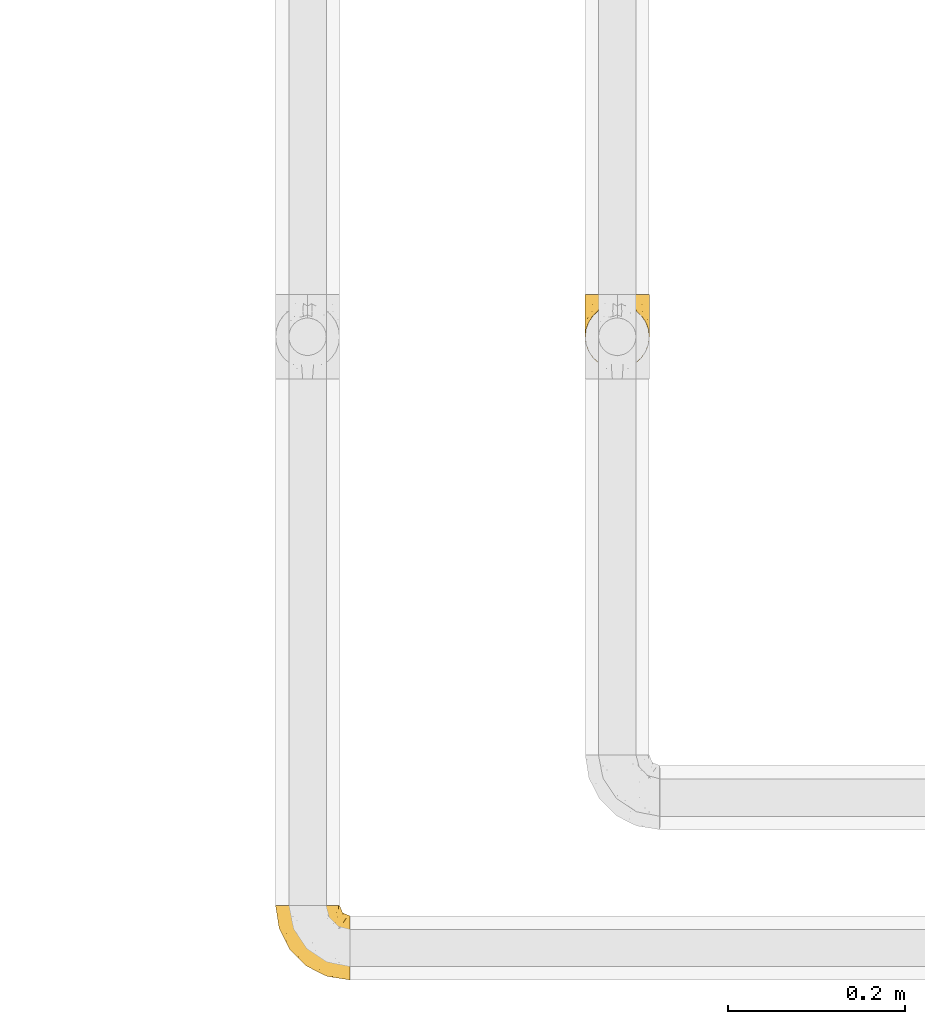
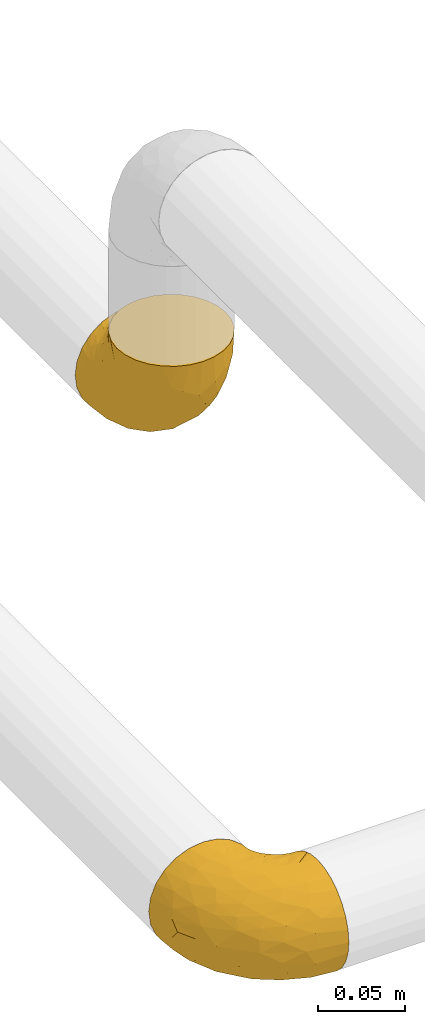
# One storey, part 7 of 39: 2 coverings.
"""IFC2X3 building model written with IfcOpenShell, lengths in millimetres."""

import ifcopenshell
import ifcopenshell.guid

model = None  # the IFC model being written
_history = None  # IfcOwnerHistory: only IFC2X3 demands one
_inside = {}  # id of a spatial element -> (the spatial element, [elements in it])
_under = {}  # id of a project, library or spatial element -> (it, [spatial elements below it])
_declared = {}  # id of a project -> (the project, [libraries it declares])
_typed = {}  # id of a type object -> (the type object, [elements of that type])
_made_of = {}  # id of a material, layer set ... -> (it, [elements and type objects made of it])


def new_model(schema):
    """Start an empty IFC model of exactly this schema.

    Asked for "IFC4X3", IfcOpenShell would pick the latest addendum, in which some entities
    have other attributes; the version numbers below select the first issue.
    IFC2X3 requires an IfcOwnerHistory on every rooted entity: one is made here for all.
    """
    global model, _history
    if schema == "IFC4X3":
        model = ifcopenshell.file(schema_version=(4, 3, 0, 0))
    else:
        model = ifcopenshell.file(schema=schema)
    _inside.clear()
    _under.clear()
    _declared.clear()
    _typed.clear()
    _made_of.clear()
    _history = None
    if model.schema == "IFC2X3":
        org = make("IfcOrganization", Name="unknown")
        user = make(
            "IfcPersonAndOrganization",
            ThePerson=make("IfcPerson", FamilyName="unknown"),
            TheOrganization=org,
        )
        app = make(
            "IfcApplication",
            ApplicationDeveloper=org,
            Version="unknown",
            ApplicationFullName="unknown",
            ApplicationIdentifier="unknown",
        )
        _history = make(
            "IfcOwnerHistory",
            OwningUser=user,
            OwningApplication=app,
            ChangeAction="ADDED",
            CreationDate=0,
        )
    return model


def make(cls, **values):
    """One entity of the class cls with the attributes given. An attribute that is None is left unset."""
    return model.create_entity(
        cls, **{name: value for name, value in values.items() if value is not None}
    )


def entity(cls, *values):
    """Any entity or typed value of the class cls, its attributes in the order of the schema. None: left unset."""
    e = model.create_entity(cls)
    for i, value in enumerate(values):
        if value is not None:
            e[i] = value
    return e


def rooted(cls, **values):
    """An entity with a GlobalId (a new one), such as an element, a storey or a relation."""
    return make(cls, GlobalId=ifcopenshell.guid.new(), OwnerHistory=_history, **values)


def si_unit(unit_type, name, prefix=None):
    """IfcSIUnit, for example si_unit("LENGTHUNIT", "METRE", prefix="MILLI")."""
    return make("IfcSIUnit", UnitType=unit_type, Prefix=prefix, Name=name)


def converted_unit(unit_type, name, factor, base, dimensions=None, offset=None):
    """IfcConversionBasedUnit, such as the inch: factor (a typed value) times the base unit."""
    return make(
        "IfcConversionBasedUnit"
        if offset is None
        else "IfcConversionBasedUnitWithOffset",
        ConversionOffset=offset,
        Dimensions=None
        if dimensions is None
        else entity("IfcDimensionalExponents", *dimensions),
        UnitType=unit_type,
        Name=name,
        ConversionFactor=make(
            "IfcMeasureWithUnit", ValueComponent=factor, UnitComponent=base
        ),
    )


def derived_unit(unit_type, elements):
    """IfcDerivedUnit: a product of units, each with its exponent."""
    return make(
        "IfcDerivedUnit",
        Elements=[
            make("IfcDerivedUnitElement", Unit=unit, Exponent=power)
            for unit, power in elements
        ],
        UnitType=unit_type,
    )


def assignment(units):
    """IfcUnitAssignment: the units of a project."""
    return None if units is None else make("IfcUnitAssignment", Units=units)


def point(xyz):
    """IfcCartesianPoint."""
    return None if xyz is None else make("IfcCartesianPoint", Coordinates=xyz)


def direction(xyz):
    """IfcDirection."""
    return None if xyz is None else make("IfcDirection", DirectionRatios=xyz)


def frame(location, z_axis=None, x_axis=None):
    """IfcAxis2Placement3D, a coordinate frame: its origin and axes. An axis left out is left unset."""
    return make(
        "IfcAxis2Placement3D",
        Location=point(location),
        Axis=direction(z_axis),
        RefDirection=direction(x_axis),
    )


def origin():
    """The frame at (0, 0, 0) with its axes left unset."""
    return frame((0.0, 0.0, 0.0))


def place(relative_to, where):
    """IfcLocalPlacement: puts the frame where relative to a parent placement (None: the world)."""
    return make(
        "IfcLocalPlacement", PlacementRelTo=relative_to, RelativePlacement=where
    )


def context(
    kind, dimensions, precision=None, world=None, true_north=None, identifier=None
):
    """IfcGeometricRepresentationContext, for example the 3D "Model" context."""
    return make(
        "IfcGeometricRepresentationContext",
        ContextIdentifier=identifier,
        ContextType=kind,
        CoordinateSpaceDimension=dimensions,
        Precision=precision,
        WorldCoordinateSystem=world,
        TrueNorth=true_north,
    )


def subcontext(parent, identifier, kind, view, scale=None):
    """IfcGeometricRepresentationSubContext, for example "Body" below "Model"."""
    return make(
        "IfcGeometricRepresentationSubContext",
        ContextIdentifier=identifier,
        ContextType=kind,
        ParentContext=parent,
        TargetScale=scale,
        TargetView=view,
    )


def project(units=None, contexts=None):
    """IfcProject with its units and contexts."""
    return rooted(
        "IfcProject",
        Name="project",
        RepresentationContexts=contexts,
        UnitsInContext=assignment(units),
    )


def spatial(cls, under=None, at=None, **own):
    """A site, building, storey or space (cls), placed at a placement, below another one or the project."""
    s = rooted(cls, ObjectPlacement=at, **own)
    if under is not None:
        _under.setdefault(under.id(), (under, []))[1].append(s)
    return s


def faces_of(points, faces, orient=None, outer=None):
    """IfcFace entities. A face is a list of loops; a loop is a list of indices into points, from 0.

    orient and outer hold one flag for each loop. By default every Orientation is true, the
    first loop of a face is its IfcFaceOuterBound and the others are IfcFaceBound.
    """
    made = []
    for i, loops in enumerate(faces):
        bounds = []
        for j, loop in enumerate(loops):
            is_outer = j == 0 if outer is None else outer[i][j]
            bounds.append(
                make(
                    "IfcFaceOuterBound" if is_outer else "IfcFaceBound",
                    Bound=make("IfcPolyLoop", Polygon=[points[k] for k in loop]),
                    Orientation=True if orient is None else orient[i][j],
                )
            )
        made.append(make("IfcFace", Bounds=bounds))
    return made


def faceted_brep(points, faces, orient=None, outer=None, voids=None):
    """IfcFacetedBrep: a solid bounded by flat faces; with voids (closed shells), ...WithVoids."""
    shared = [point(p) for p in points]
    hull = make("IfcClosedShell", CfsFaces=faces_of(shared, faces, orient, outer))
    if voids is None:
        return make("IfcFacetedBrep", Outer=hull)
    return make(
        "IfcFacetedBrepWithVoids",
        Outer=hull,
        Voids=[
            make(cls, CfsFaces=faces_of(shared, fs, o, b)) for cls, fs, o, b in voids
        ],
    )


def shape(context_of_items, identifier, shape_type, items):
    """IfcShapeRepresentation: the items that make up one representation, for example the "Body"."""
    return make(
        "IfcShapeRepresentation",
        ContextOfItems=context_of_items,
        RepresentationIdentifier=identifier,
        RepresentationType=shape_type,
        Items=items,
    )


def made_of(thing, what):
    """Note that an element or type object is made of a material, layer set ...; save() writes the relation."""
    if what is not None:
        _made_of.setdefault(what.id(), (what, []))[1].append(thing)
    return thing


def element(
    cls,
    number,
    at=None,
    inside=None,
    cuts=None,
    type_object=None,
    material=None,
    context=None,
    identifier="Body",
    shape_type=None,
    held_by="IfcProductDefinitionShape",
    body=None,
    shapes=None,
    **own,
):
    """One element of the class cls, such as IfcWall. Its Tag is "e" and its number.

    at: its placement. inside: the storey or other place that contains it. cuts: it is an
    opening in that element (IfcRelVoidsElement). A single representation is given by context,
    identifier, shape_type and body (its items); several are given by shapes. held_by: the class
    of the entity that holds the representations. save() writes the other relations.
    """
    e = rooted(cls, Tag="e%d" % number, ObjectPlacement=at, **own)
    if body is not None:
        shapes = [shape(context, identifier, shape_type, body)]
    if shapes is not None:
        e.Representation = make(held_by, Representations=shapes)
    if inside is not None:
        _inside.setdefault(inside.id(), (inside, []))[1].append(e)
    if cuts is not None:
        rooted(
            "IfcRelVoidsElement", RelatingBuildingElement=cuts, RelatedOpeningElement=e
        )
    if type_object is not None:
        _typed.setdefault(type_object.id(), (type_object, []))[1].append(e)
    return made_of(e, material)


def aggregate(whole, parts):
    """IfcRelAggregates: a whole, such as a stair, and the parts it consists of."""
    return rooted("IfcRelAggregates", RelatingObject=whole, RelatedObjects=parts)


def save(model, path):
    """Write the relations noted so far, then the file.

    IfcRelAggregates (storeys below a building ...), IfcRelContainedInSpatialStructure (elements
    in a storey), IfcRelDefinesByType, IfcRelAssociatesMaterial and IfcRelDeclares: one each for
    every whole, place, type object, material and project.
    """
    for whole, parts in _under.values():
        aggregate(whole, parts)
    for where, things in _inside.values():
        rooted(
            "IfcRelContainedInSpatialStructure",
            RelatedElements=things,
            RelatingStructure=where,
        )
    for kind, things in _typed.values():
        rooted("IfcRelDefinesByType", RelatedObjects=things, RelatingType=kind)
    for what, things in _made_of.values():
        rooted("IfcRelAssociatesMaterial", RelatedObjects=things, RelatingMaterial=what)
    for by, libraries in _declared.values():
        rooted("IfcRelDeclares", RelatingContext=by, RelatedDefinitions=libraries)
    model.write(path)


model = new_model("IFC2X3")

# Units and contexts
model_context = context("Model", 3, precision=0.01, world=origin(), true_north=direction((6.12303176911189e-17, 1.0)))
body_context = subcontext(model_context, "Body", "Model", "MODEL_VIEW")
ifc_project = project(units=[si_unit("LENGTHUNIT", "METRE", prefix="MILLI"), si_unit("AREAUNIT", "SQUARE_METRE"), si_unit("VOLUMEUNIT", "CUBIC_METRE"), converted_unit("PLANEANGLEUNIT", "DEGREE", entity("IfcRatioMeasure", 0.0174532925199433), si_unit("PLANEANGLEUNIT", "RADIAN"), dimensions=[0, 0, 0, 0, 0, 0, 0]), si_unit("MASSUNIT", "GRAM", prefix="KILO"), derived_unit("MASSDENSITYUNIT", [(si_unit("MASSUNIT", "GRAM", prefix="KILO"), 1), (si_unit("LENGTHUNIT", "METRE"), -3)]), derived_unit("MOMENTOFINERTIAUNIT", [(si_unit("LENGTHUNIT", "METRE"), 4)]), si_unit("TIMEUNIT", "SECOND"), si_unit("FREQUENCYUNIT", "HERTZ"), si_unit("THERMODYNAMICTEMPERATUREUNIT", "DEGREE_CELSIUS"), derived_unit("THERMALTRANSMITTANCEUNIT", [(si_unit("MASSUNIT", "GRAM", prefix="KILO"), 1), (si_unit("THERMODYNAMICTEMPERATUREUNIT", "KELVIN"), -1), (si_unit("TIMEUNIT", "SECOND"), -3)]), derived_unit("VOLUMETRICFLOWRATEUNIT", [(si_unit("LENGTHUNIT", "METRE"), 3), (si_unit("TIMEUNIT", "SECOND"), -1)]), derived_unit("MASSFLOWRATEUNIT", [(si_unit("MASSUNIT", "GRAM", prefix="KILO"), 1), (si_unit("TIMEUNIT", "SECOND"), -1)]), derived_unit("ROTATIONALFREQUENCYUNIT", [(si_unit("TIMEUNIT", "SECOND"), -1)]), si_unit("ELECTRICCURRENTUNIT", "AMPERE"), si_unit("ELECTRICVOLTAGEUNIT", "VOLT"), si_unit("POWERUNIT", "WATT"), si_unit("FORCEUNIT", "NEWTON", prefix="KILO"), si_unit("ILLUMINANCEUNIT", "LUX"), si_unit("LUMINOUSFLUXUNIT", "LUMEN"), si_unit("LUMINOUSINTENSITYUNIT", "CANDELA"), derived_unit("USERDEFINED", [(si_unit("MASSUNIT", "GRAM", prefix="KILO"), -1), (si_unit("LENGTHUNIT", "METRE"), -2), (si_unit("TIMEUNIT", "SECOND"), 3), (si_unit("LUMINOUSFLUXUNIT", "LUMEN"), 1)]), derived_unit("LINEARVELOCITYUNIT", [(si_unit("LENGTHUNIT", "METRE"), 1), (si_unit("TIMEUNIT", "SECOND"), -1)]), si_unit("PRESSUREUNIT", "PASCAL"), derived_unit("USERDEFINED", [(si_unit("LENGTHUNIT", "METRE"), -2), (si_unit("MASSUNIT", "GRAM", prefix="KILO"), 1), (si_unit("TIMEUNIT", "SECOND"), -2)]), derived_unit("LINEARFORCEUNIT", [(si_unit("MASSUNIT", "GRAM", prefix="KILO"), 1), (si_unit("LENGTHUNIT", "METRE"), 1), (si_unit("TIMEUNIT", "SECOND"), -2), (si_unit("LENGTHUNIT", "METRE"), -1)]), derived_unit("PLANARFORCEUNIT", [(si_unit("MASSUNIT", "GRAM", prefix="KILO"), 1), (si_unit("LENGTHUNIT", "METRE"), 1), (si_unit("TIMEUNIT", "SECOND"), -2), (si_unit("LENGTHUNIT", "METRE"), -2)])], contexts=[model_context])

# Site, building, storey
site_placement = place(None, origin())
site = spatial("IfcSite", under=ifc_project, at=site_placement, CompositionType="ELEMENT")
building_placement = place(site_placement, origin())
building = spatial("IfcBuilding", under=site, at=building_placement, CompositionType="ELEMENT")
storey_placement = place(building_placement, frame((0.0, 0.0, 24000.0)))
storey = spatial("IfcBuildingStorey", under=building, at=storey_placement, Name="07", CompositionType="ELEMENT", Elevation=24000.0)

# Coverings
covering_1_placement = place(storey_placement, frame((31042.2, 1393.38, 2787.62)))
element("IfcCovering", 1, at=covering_1_placement, inside=storey, Name=":ADSK_", ObjectType=":ADSK_", PredefinedType="INSULATION", context=body_context, shape_type="Brep", body=[
    faceted_brep([(85.72, 37.8, 74.09), (85.72, 29.74, 73.18), (85.73, 22.08, 70.5), (85.74, 15.22, 66.19), (85.75, 9.49, 60.46), (85.76, 5.18, 53.59), (85.78, 2.5, 45.94), (85.8, 1.6, 37.89), (85.81, 2.5, 29.83), (85.83, 5.18, 22.18), (85.84, 9.5, 15.32), (85.85, 15.23, 9.58), (85.86, 22.09, 5.27), (85.87, 29.74, 2.6), (85.87, 37.8, 1.69), (85.87, 43.06, 2.28), (85.87, 45.85, 2.6), (85.86, 49.68, 3.94), (85.86, 53.51, 5.28), (85.85, 60.37, 9.59), (85.84, 66.1, 15.33), (85.83, 70.41, 22.19), (85.81, 73.09, 29.84), (85.8, 74.0, 37.89), (85.78, 73.09, 45.95), (85.76, 70.41, 53.6), (85.75, 66.09, 60.47), (85.74, 60.36, 66.2), (85.73, 53.5, 70.51), (85.73, 49.67, 71.85), (85.72, 45.85, 73.18), (85.72, 43.06, 73.5), (72.78, 85.8, 28.5), (69.18, 85.8, 19.76), (63.44, 85.8, 12.25), (59.7, 85.8, 9.37), (55.96, 85.8, 6.48), (51.6, 85.8, 4.66), (47.23, 85.8, 2.85), (43.15, 85.8, 2.3), (40.51, 85.8, 1.95), (37.87, 85.8, 1.6), (28.5, 85.8, 2.81), (19.76, 85.8, 6.41), (12.25, 85.8, 12.15), (6.48, 85.8, 19.63), (2.85, 85.8, 28.36), (1.6, 85.8, 37.72), (2.81, 85.8, 47.09), (6.41, 85.8, 55.83), (12.15, 85.8, 63.34), (19.63, 85.8, 69.11), (28.36, 85.8, 72.74), (37.72, 85.8, 74.0), (43.01, 85.8, 73.31), (47.09, 85.8, 72.78), (51.46, 85.8, 70.98), (55.83, 85.8, 69.18), (59.59, 85.8, 66.31), (63.34, 85.8, 63.44), (69.11, 85.8, 55.96), (72.74, 85.8, 47.23), (74.0, 85.8, 37.87), (27.76, 27.78, 50.09), (26.99, 26.99, 37.77), (36.06, 19.15, 46.43), (5.72, 59.78, 37.73), (4.89, 64.45, 43.96), (4.42, 67.99, 37.73), (13.5, 45.3, 47.54), (13.96, 53.86, 57.12), (6.25, 66.01, 50.31), (9.6, 70.92, 58.59), (70.86, 33.16, 73.44), (35.99, 49.16, 71.27), (23.96, 68.28, 70.14), (25.87, 50.64, 66.95), (32.49, 70.36, 73.21), (41.38, 67.43, 74.0), (39.89, 74.88, 74.0), (39.35, 77.61, 74.0), (38.81, 80.34, 74.0), (16.57, 65.68, 64.82), (71.57, 24.84, 71.0), (47.82, 11.5, 45.21), (65.89, 5.67, 48.62), (51.34, 13.35, 54.35), (52.74, 39.73, 72.97), (67.35, 41.45, 74.05), (63.46, 44.05, 74.05), (59.57, 46.65, 74.04), (55.67, 49.25, 74.03), (51.78, 51.85, 74.02), (41.19, 35.98, 68.73), (38.91, 57.18, 73.34), (70.59, 18.48, 67.34), (65.59, 13.36, 61.76), (71.04, 7.85, 56.0), (67.99, 4.42, 37.86), (38.59, 20.15, 53.02), (28.69, 31.91, 57.29), (80.26, 38.88, 74.08), (74.81, 39.97, 74.07), (52.47, 21.9, 64.89), (41.64, 22.4, 59.16), (56.38, 28.44, 70.09), (19.86, 41.69, 55.95), (11.7, 48.04, 37.74), (33.99, 33.67, 63.53), (22.62, 44.49, 61.37), (59.78, 5.72, 37.84), (36.3, 17.68, 37.79), (48.04, 11.7, 37.82), (49.18, 55.75, 74.02), (46.58, 59.64, 74.01), (43.98, 63.53, 74.01), (17.68, 36.3, 37.76), (56.4, 69.92, 70.93), (60.86, 69.03, 69.25), (63.24, 74.68, 65.88), (45.24, 79.55, 73.32), (54.65, 80.23, 70.09), (59.77, 79.54, 67.12), (74.46, 76.19, 52.37), (76.79, 72.4, 55.02), (77.99, 75.54, 46.62), (47.3, 70.42, 73.4), (54.32, 74.75, 70.91), (64.66, 81.25, 62.58), (76.89, 46.01, 73.34), (68.25, 80.78, 58.42), (70.8, 77.88, 56.43), (73.15, 80.8, 49.06), (71.95, 72.9, 59.39), (56.83, 63.7, 72.12), (50.11, 66.91, 73.19), (62.12, 52.1, 73.39), (67.66, 50.98, 72.97), (74.25, 68.99, 61.25), (78.12, 66.56, 61.64), (75.47, 51.42, 71.98), (80.75, 76.08, 37.88), (77.45, 77.45, 37.87), (66.41, 71.01, 65.25), (76.08, 80.75, 37.87), (81.7, 73.72, 46.13), (72.58, 63.33, 66.64), (73.77, 58.7, 69.05), (81.66, 71.61, 52.24), (80.68, 60.93, 66.14), (48.19, 76.87, 72.77), (62.76, 63.89, 70.19), (62.24, 57.77, 72.19), (68.8, 66.53, 66.34), (56.46, 57.73, 73.26), (68.33, 80.78, 17.3), (73.19, 80.8, 26.67), (64.76, 81.26, 13.12), (80.41, 38.88, 1.68), (74.95, 39.97, 1.67), (81.73, 73.72, 29.65), (76.86, 72.41, 20.74), (81.72, 71.61, 23.53), (78.22, 66.57, 14.13), (38.41, 83.07, 1.6), (40.04, 74.88, 1.6), (38.95, 80.34, 1.6), (70.87, 77.88, 19.29), (74.52, 76.2, 23.38), (72.04, 72.91, 16.36), (59.93, 77.2, 8.13), (54.45, 74.75, 4.75), (54.78, 80.23, 5.57), (75.6, 51.43, 3.77), (48.33, 76.87, 2.86), (50.25, 66.92, 2.45), (56.53, 69.93, 4.73), (56.97, 63.71, 3.55), (47.44, 70.42, 2.22), (78.03, 75.54, 29.13), (45.38, 79.55, 2.3), (80.79, 60.94, 9.63), (74.35, 69.0, 14.5), (77.03, 46.02, 2.41), (62.38, 57.77, 3.5), (56.61, 57.73, 2.41), (62.89, 63.89, 5.5), (66.52, 71.03, 10.46), (67.89, 51.53, 2.87), (73.89, 58.72, 6.69), (67.5, 41.45, 1.65), (63.35, 74.69, 9.81), (72.69, 63.35, 9.1), (67.46, 56.44, 4.21), (62.19, 51.59, 2.21), (63.61, 44.05, 1.65), (46.72, 59.64, 1.61), (49.33, 55.75, 1.62), (41.52, 67.43, 1.6), (44.12, 63.53, 1.61), (60.99, 69.03, 6.44), (68.91, 66.54, 9.38), (59.71, 46.65, 1.64), (51.93, 51.85, 1.62), (55.82, 49.25, 1.63), (36.12, 49.16, 4.31), (32.63, 70.36, 2.36), (39.05, 57.19, 2.25), (41.73, 22.41, 16.44), (28.76, 31.92, 18.26), (34.1, 33.68, 12.04), (25.99, 50.63, 8.59), (41.33, 35.99, 6.87), (52.58, 21.91, 10.75), (52.88, 39.73, 2.67), (27.81, 27.78, 25.46), (19.94, 41.7, 19.56), (24.09, 68.28, 5.4), (4.92, 64.45, 31.5), (6.3, 66.0, 25.15), (56.51, 28.45, 5.57), (9.69, 70.92, 16.89), (16.68, 65.68, 10.68), (14.04, 53.85, 18.38), (51.41, 13.35, 21.29), (65.93, 5.67, 27.07), (47.84, 11.5, 30.41), (71.01, 33.16, 2.28), (65.69, 13.37, 13.94), (70.71, 18.49, 8.37), (13.54, 45.3, 27.95), (36.1, 19.14, 29.14), (38.65, 20.15, 22.56), (71.11, 7.85, 19.71), (22.73, 44.48, 14.15), (71.7, 24.85, 4.72)], [[[0, 1, 2, 3, 4, 5, 6, 7, 8, 9, 10, 11, 12, 13, 14, 15, 16, 17, 18, 19, 20, 21, 22, 23, 24, 25, 26, 27, 28, 29, 30, 31]], [[32, 33, 34, 35, 36, 37, 38, 39, 40, 41, 42, 43, 44, 45, 46, 47, 48, 49, 50, 51, 52, 53, 54, 55, 56, 57, 58, 59, 60, 61, 62]], [[63, 64, 65]], [[66, 67, 68]], [[69, 70, 71]], [[71, 70, 72]], [[73, 1, 0]], [[74, 75, 76]], [[49, 48, 71]], [[77, 78, 79, 80, 81, 53]], [[50, 82, 51]], [[72, 50, 49]], [[2, 1, 83]], [[84, 85, 86]], [[87, 88, 89, 90, 91, 92]], [[53, 52, 77]], [[93, 74, 76]], [[5, 85, 6]], [[94, 78, 77]], [[95, 3, 2]], [[95, 96, 3]], [[75, 51, 82]], [[85, 5, 97]], [[50, 72, 82]], [[97, 5, 4]], [[85, 98, 6]], [[94, 87, 92]], [[74, 77, 75]], [[99, 100, 63]], [[96, 4, 3]], [[73, 0, 101, 102, 88]], [[96, 103, 104]], [[48, 68, 67]], [[84, 99, 65]], [[105, 83, 73]], [[105, 95, 83]], [[100, 106, 63]], [[86, 96, 104]], [[97, 86, 85]], [[67, 107, 69]], [[100, 108, 109]], [[84, 110, 85]], [[93, 87, 74]], [[96, 95, 103]], [[69, 71, 67]], [[70, 69, 106]], [[4, 96, 97]], [[86, 97, 96]], [[83, 95, 2]], [[103, 95, 105]], [[93, 103, 105]], [[103, 108, 104]], [[75, 77, 52]], [[94, 77, 74]], [[51, 75, 52]], [[75, 82, 76]], [[109, 82, 70]], [[93, 76, 108]], [[88, 87, 73]], [[105, 73, 87]], [[84, 86, 99]], [[84, 111, 112, 110]], [[98, 85, 110]], [[98, 7, 6]], [[73, 83, 1]], [[71, 72, 49]], [[82, 72, 70]], [[87, 94, 74]], [[94, 92, 113, 114, 115, 78]], [[48, 47, 68]], [[48, 67, 71]], [[100, 104, 108]], [[99, 86, 104]], [[109, 108, 76]], [[100, 109, 106]], [[82, 109, 76]], [[106, 109, 70]], [[100, 99, 104]], [[99, 63, 65]], [[69, 116, 63]], [[111, 84, 65]], [[64, 63, 116]], [[64, 111, 65]], [[63, 106, 69]], [[103, 93, 108]], [[87, 93, 105]], [[107, 67, 66]], [[107, 116, 69]], [[117, 118, 119]], [[80, 120, 55]], [[55, 120, 56]], [[58, 121, 122]], [[123, 124, 125]], [[126, 127, 121]], [[128, 60, 59]], [[128, 122, 119]], [[29, 28, 129]], [[60, 130, 61]], [[131, 123, 132]], [[101, 0, 31, 30, 102]], [[133, 124, 123]], [[114, 134, 135]], [[136, 90, 137]], [[124, 133, 138]], [[26, 25, 139]], [[140, 28, 27]], [[140, 129, 28]], [[102, 29, 129]], [[125, 141, 142]], [[130, 132, 61]], [[119, 118, 143]], [[144, 125, 142]], [[23, 141, 145]], [[139, 146, 147]], [[60, 128, 130]], [[54, 53, 81, 80, 55]], [[25, 148, 139]], [[24, 148, 25]], [[124, 145, 125]], [[27, 26, 149]], [[124, 148, 145]], [[149, 139, 147]], [[150, 57, 56]], [[126, 78, 115]], [[132, 62, 61]], [[149, 140, 27]], [[151, 152, 153]], [[140, 147, 137]], [[137, 89, 140]], [[120, 78, 150]], [[115, 135, 126]], [[126, 121, 150]], [[78, 120, 80, 79]], [[150, 56, 120]], [[152, 151, 154]], [[135, 117, 127]], [[148, 24, 145]], [[139, 148, 124]], [[152, 91, 136]], [[146, 152, 147]], [[23, 145, 24]], [[141, 125, 145]], [[132, 125, 144]], [[133, 123, 131]], [[143, 131, 119]], [[124, 138, 139]], [[125, 132, 123]], [[62, 132, 144]], [[133, 153, 138]], [[146, 138, 153]], [[92, 154, 113]], [[135, 115, 114]], [[117, 135, 134]], [[118, 117, 134]], [[122, 117, 119]], [[127, 126, 135]], [[78, 126, 150]], [[151, 118, 134]], [[118, 151, 143]], [[153, 133, 143]], [[131, 143, 133]], [[102, 30, 29]], [[140, 88, 129]], [[88, 102, 129]], [[139, 149, 26]], [[140, 149, 147]], [[122, 128, 59]], [[130, 119, 131]], [[122, 59, 58]], [[122, 127, 117]], [[121, 58, 57]], [[150, 121, 57]], [[122, 121, 127]], [[119, 130, 128]], [[130, 131, 132]], [[138, 146, 139]], [[152, 146, 153]], [[89, 137, 90]], [[89, 88, 140]], [[136, 147, 152]], [[147, 136, 137]], [[134, 114, 113]], [[152, 154, 91]], [[91, 90, 136]], [[151, 153, 143]], [[154, 151, 134]], [[113, 154, 134]], [[91, 154, 92]], [[155, 32, 156]], [[33, 157, 34]], [[62, 144, 156]], [[15, 14, 158, 159, 16]], [[160, 23, 22]], [[161, 162, 163]], [[164, 41, 40, 39, 38, 165, 166]], [[167, 168, 169]], [[157, 170, 34]], [[171, 172, 170]], [[18, 173, 19]], [[174, 37, 36]], [[175, 176, 177]], [[178, 171, 175]], [[142, 179, 144]], [[168, 179, 161]], [[161, 160, 162]], [[162, 160, 22]], [[38, 37, 180]], [[20, 19, 181]], [[21, 20, 163]], [[161, 182, 169]], [[18, 183, 173]], [[184, 185, 186]], [[169, 187, 167]], [[188, 189, 173]], [[159, 190, 183]], [[17, 159, 183]], [[156, 179, 168]], [[191, 157, 155]], [[192, 163, 189]], [[21, 162, 22]], [[142, 141, 179]], [[181, 163, 20]], [[177, 186, 185]], [[178, 172, 171]], [[167, 156, 168]], [[184, 193, 194]], [[181, 173, 189]], [[173, 195, 188]], [[196, 177, 197]], [[198, 165, 180]], [[180, 165, 38]], [[199, 178, 175]], [[37, 174, 180]], [[198, 180, 174]], [[175, 196, 199]], [[177, 176, 200]], [[163, 162, 21]], [[160, 161, 179]], [[192, 184, 201]], [[193, 189, 188]], [[179, 141, 160]], [[23, 160, 141]], [[169, 168, 161]], [[155, 156, 167]], [[182, 161, 163]], [[201, 186, 187]], [[62, 156, 32]], [[179, 156, 144]], [[192, 182, 163]], [[201, 169, 182]], [[176, 175, 171]], [[174, 178, 198]], [[196, 175, 177]], [[170, 176, 171]], [[200, 176, 191]], [[198, 178, 199]], [[178, 174, 172]], [[187, 200, 191]], [[200, 187, 186]], [[167, 187, 191]], [[169, 201, 187]], [[173, 183, 190]], [[17, 16, 159]], [[173, 181, 19]], [[163, 181, 189]], [[155, 157, 33]], [[170, 157, 191]], [[176, 170, 191]], [[35, 170, 172]], [[35, 172, 36]], [[34, 170, 35]], [[174, 36, 172]], [[32, 155, 33]], [[191, 155, 167]], [[192, 189, 193]], [[182, 192, 201]], [[185, 197, 177]], [[183, 18, 17]], [[195, 173, 190]], [[195, 202, 188]], [[200, 186, 177]], [[201, 184, 186]], [[188, 194, 193]], [[203, 185, 204]], [[188, 202, 194]], [[192, 193, 184]], [[202, 204, 194]], [[184, 194, 204]], [[204, 185, 184]], [[197, 185, 203]], [[205, 206, 207]], [[208, 209, 210]], [[210, 211, 212]], [[210, 213, 208]], [[214, 203, 204, 202, 195, 190]], [[206, 41, 164, 166, 165, 198]], [[215, 216, 209]], [[206, 217, 42]], [[218, 46, 219]], [[207, 214, 205]], [[212, 214, 220]], [[221, 219, 45]], [[45, 219, 46]], [[221, 222, 223]], [[224, 225, 226]], [[222, 44, 43]], [[222, 217, 211]], [[220, 214, 227]], [[227, 190, 159, 158, 14]], [[217, 43, 42]], [[14, 13, 227]], [[225, 9, 8]], [[10, 228, 11]], [[11, 229, 12]], [[208, 213, 228]], [[228, 229, 11]], [[230, 219, 223]], [[231, 232, 226]], [[231, 64, 215]], [[225, 233, 9]], [[229, 213, 220]], [[233, 10, 9]], [[110, 225, 98]], [[41, 206, 42]], [[222, 211, 234]], [[224, 228, 233]], [[225, 8, 98]], [[221, 45, 44]], [[226, 110, 112, 111]], [[12, 229, 235]], [[46, 218, 68]], [[230, 107, 218]], [[223, 234, 216]], [[107, 66, 218]], [[224, 233, 225]], [[228, 10, 233]], [[213, 229, 228]], [[235, 229, 220]], [[208, 228, 224]], [[212, 213, 210]], [[207, 206, 198]], [[205, 211, 217]], [[205, 217, 206]], [[43, 217, 222]], [[212, 211, 205]], [[210, 209, 234]], [[227, 13, 235]], [[214, 190, 227]], [[110, 226, 225]], [[232, 231, 215]], [[8, 7, 98]], [[227, 235, 220]], [[13, 12, 235]], [[222, 221, 44]], [[219, 221, 223]], [[207, 198, 199, 196, 197, 203]], [[214, 207, 203]], [[68, 218, 66]], [[68, 47, 46]], [[230, 218, 219]], [[224, 232, 208]], [[208, 232, 209]], [[216, 215, 230]], [[210, 234, 211]], [[216, 234, 209]], [[222, 234, 223]], [[226, 232, 224]], [[209, 232, 215]], [[226, 111, 231]], [[64, 116, 215]], [[231, 111, 64]], [[116, 230, 215]], [[230, 223, 216]], [[214, 212, 205]], [[213, 212, 220]], [[230, 116, 107]]]),
])
covering_2_placement = place(storey_placement, frame((31392.2, 2084.16, 2622.2)))
element("IfcCovering", 2, at=covering_2_placement, inside=storey, Name=":ADSK_", ObjectType=":ADSK_", PredefinedType="INSULATION", context=body_context, shape_type="Brep", body=[
    faceted_brep([(1.6, 37.8, 85.8), (2.5, 29.74, 85.8), (5.18, 22.08, 85.8), (9.5, 15.22, 85.8), (15.23, 9.49, 85.8), (22.09, 5.18, 85.8), (29.74, 2.5, 85.8), (37.8, 1.6, 85.8), (45.85, 2.5, 85.8), (53.51, 5.18, 85.8), (60.37, 9.5, 85.8), (66.1, 15.23, 85.8), (70.41, 22.09, 85.8), (73.09, 29.74, 85.8), (74.0, 37.8, 85.8), (73.4, 43.06, 85.8), (73.09, 45.85, 85.8), (71.75, 49.68, 85.8), (70.41, 53.51, 85.8), (66.09, 60.37, 85.8), (60.36, 66.1, 85.8), (53.5, 70.41, 85.8), (45.85, 73.09, 85.8), (37.8, 74.0, 85.8), (29.74, 73.09, 85.8), (22.08, 70.41, 85.8), (15.22, 66.09, 85.8), (9.49, 60.36, 85.8), (5.18, 53.5, 85.8), (3.84, 49.67, 85.8), (2.5, 45.85, 85.8), (2.19, 43.06, 85.8), (47.16, 85.8, 72.76), (55.9, 85.8, 69.15), (63.39, 85.8, 63.39), (66.27, 85.8, 59.64), (69.15, 85.8, 55.9), (70.95, 85.8, 51.53), (72.76, 85.8, 47.16), (73.3, 85.8, 43.08), (73.65, 85.8, 40.44), (74.0, 85.8, 37.8), (72.76, 85.8, 28.43), (69.15, 85.8, 19.7), (63.39, 85.8, 12.2), (55.9, 85.8, 6.45), (47.16, 85.8, 2.83), (37.8, 85.8, 1.6), (28.43, 85.8, 2.83), (19.7, 85.8, 6.45), (12.2, 85.8, 12.2), (6.45, 85.8, 19.7), (2.83, 85.8, 28.43), (1.6, 85.8, 37.8), (2.29, 85.8, 43.08), (2.83, 85.8, 47.16), (4.64, 85.8, 51.53), (6.45, 85.8, 55.9), (9.32, 85.8, 59.64), (12.2, 85.8, 63.39), (19.7, 85.8, 69.15), (28.43, 85.8, 72.76), (37.8, 85.8, 74.0), (25.48, 27.78, 27.78), (37.8, 26.99, 26.99), (29.15, 19.15, 36.07), (37.8, 59.78, 5.72), (31.57, 64.45, 4.9), (37.8, 67.99, 4.42), (28.0, 45.3, 13.52), (18.42, 53.86, 14.0), (25.21, 66.01, 6.28), (16.94, 70.92, 9.64), (2.22, 33.16, 70.93), (4.32, 49.16, 36.05), (5.43, 68.28, 24.02), (8.62, 50.64, 25.93), (2.37, 70.36, 32.56), (1.6, 67.43, 41.45), (1.6, 74.88, 39.97), (1.6, 77.61, 39.42), (1.6, 80.34, 38.88), (10.73, 65.68, 16.62), (4.66, 24.84, 71.64), (30.4, 11.5, 47.83), (27.02, 5.67, 65.91), (21.27, 13.35, 51.38), (2.65, 39.73, 52.81), (1.6, 41.45, 67.43), (1.6, 44.05, 63.53), (1.6, 46.65, 59.64), (1.6, 49.25, 55.75), (1.6, 51.85, 51.85), (6.87, 35.98, 41.26), (2.25, 57.18, 38.98), (8.31, 18.48, 70.65), (13.89, 13.36, 65.64), (19.66, 7.85, 71.08), (37.8, 4.42, 67.99), (22.57, 20.15, 38.62), (18.28, 31.91, 28.73), (1.6, 38.88, 80.34), (1.6, 39.97, 74.88), (10.73, 21.9, 52.52), (16.44, 22.4, 41.68), (5.54, 28.44, 56.44), (19.61, 41.69, 19.89), (37.8, 48.04, 11.7), (12.05, 33.67, 34.04), (14.19, 44.49, 22.66), (37.8, 5.72, 59.78), (37.8, 17.68, 36.3), (37.8, 11.7, 48.04), (1.6, 55.75, 49.25), (1.6, 59.64, 46.65), (1.6, 63.53, 44.05), (37.8, 36.3, 17.68), (4.69, 69.92, 56.47), (6.39, 69.03, 60.92), (9.76, 74.68, 63.29), (2.29, 79.55, 45.31), (8.52, 79.54, 59.83), (13.06, 81.25, 64.71), (23.29, 76.19, 74.49), (20.65, 72.4, 76.83), (29.05, 75.54, 78.01), (3.51, 63.7, 56.9), (2.42, 66.91, 50.18), (16.27, 72.9, 71.99), (19.23, 77.88, 70.83), (26.6, 80.8, 73.18), (17.24, 80.78, 68.29), (9.54, 60.93, 80.74), (14.03, 66.56, 78.17), (6.61, 58.7, 73.83), (2.33, 46.01, 76.96), (5.54, 80.23, 54.72), (2.2, 70.42, 47.37), (4.72, 74.75, 54.39), (14.42, 68.99, 74.3), (3.69, 51.42, 75.54), (10.4, 71.01, 66.46), (37.8, 76.08, 80.75), (29.55, 73.72, 81.71), (23.44, 71.61, 81.69), (9.02, 63.33, 72.63), (37.8, 77.45, 77.45), (2.25, 52.1, 62.19), (2.68, 50.98, 67.73), (37.8, 80.75, 76.08), (2.84, 76.87, 48.26), (5.45, 63.89, 62.83), (3.45, 57.77, 62.31), (9.31, 66.53, 68.86), (2.37, 57.73, 56.53), (58.36, 80.78, 68.29), (48.99, 80.8, 73.17), (62.53, 81.26, 64.71), (74.0, 38.88, 80.34), (74.0, 39.97, 74.88), (46.03, 73.72, 81.71), (54.93, 72.41, 76.83), (52.14, 71.61, 81.69), (61.55, 66.57, 78.17), (74.0, 74.88, 39.97), (74.0, 80.34, 38.88), (74.0, 83.07, 38.34), (56.36, 77.88, 70.83), (52.29, 76.2, 74.49), (59.3, 72.91, 72.0), (67.5, 77.2, 59.87), (70.87, 74.75, 54.39), (70.05, 80.23, 54.72), (71.9, 51.43, 75.53), (72.75, 76.87, 48.26), (73.17, 66.92, 50.18), (70.9, 69.93, 56.47), (72.08, 63.71, 56.9), (73.39, 70.42, 47.37), (46.54, 75.54, 78.01), (73.31, 79.55, 45.31), (66.04, 60.94, 80.74), (61.17, 69.0, 74.3), (73.26, 46.02, 76.96), (72.14, 57.77, 62.32), (73.22, 57.73, 56.54), (70.14, 63.89, 62.83), (65.18, 71.03, 66.46), (72.78, 51.53, 67.82), (68.97, 58.72, 73.83), (74.0, 41.45, 67.43), (65.83, 74.69, 63.29), (66.56, 63.35, 72.63), (74.0, 59.64, 46.65), (71.44, 56.44, 67.39), (73.42, 51.59, 62.12), (74.0, 44.05, 63.53), (69.2, 69.03, 60.93), (74.0, 67.43, 41.45), (74.0, 63.53, 44.05), (66.27, 66.54, 68.85), (74.0, 55.75, 49.25), (74.0, 49.25, 55.75), (74.0, 46.65, 59.64), (74.0, 51.85, 51.85), (71.27, 49.16, 36.06), (73.22, 70.36, 32.56), (73.34, 57.19, 38.98), (59.16, 22.41, 41.69), (57.32, 31.92, 28.73), (63.55, 33.68, 34.05), (66.97, 50.63, 25.93), (68.72, 35.99, 41.26), (64.87, 21.91, 52.53), (72.95, 39.73, 52.81), (50.11, 27.78, 27.78), (56.0, 41.7, 19.9), (70.16, 68.28, 24.02), (44.03, 64.45, 4.9), (50.38, 66.0, 6.28), (70.06, 28.45, 56.45), (58.65, 70.92, 9.64), (64.86, 65.68, 16.62), (57.17, 53.85, 14.0), (54.33, 13.35, 51.38), (48.58, 5.67, 65.91), (45.2, 11.5, 47.82), (73.37, 33.16, 70.94), (61.71, 13.37, 65.64), (67.29, 18.49, 70.65), (47.59, 45.3, 13.52), (46.45, 19.14, 36.08), (53.03, 20.15, 38.62), (55.95, 7.85, 71.07), (61.41, 44.48, 22.68), (70.93, 24.85, 71.64)], [[[0, 1, 2, 3, 4, 5, 6, 7, 8, 9, 10, 11, 12, 13, 14, 15, 16, 17, 18, 19, 20, 21, 22, 23, 24, 25, 26, 27, 28, 29, 30, 31]], [[32, 33, 34, 35, 36, 37, 38, 39, 40, 41, 42, 43, 44, 45, 46, 47, 48, 49, 50, 51, 52, 53, 54, 55, 56, 57, 58, 59, 60, 61, 62]], [[63, 64, 65]], [[66, 67, 68]], [[69, 70, 71]], [[71, 70, 72]], [[73, 1, 0]], [[74, 75, 76]], [[49, 48, 71]], [[77, 78, 79, 80, 81, 53]], [[50, 82, 51]], [[72, 50, 49]], [[2, 1, 83]], [[84, 85, 86]], [[87, 88, 89, 90, 91, 92]], [[53, 52, 77]], [[93, 74, 76]], [[5, 85, 6]], [[94, 78, 77]], [[95, 3, 2]], [[95, 96, 3]], [[75, 51, 82]], [[85, 5, 97]], [[50, 72, 82]], [[97, 5, 4]], [[85, 98, 6]], [[94, 87, 92]], [[74, 77, 75]], [[99, 100, 63]], [[96, 4, 3]], [[73, 0, 101, 102, 88]], [[96, 103, 104]], [[48, 68, 67]], [[84, 99, 65]], [[105, 83, 73]], [[105, 95, 83]], [[100, 106, 63]], [[86, 96, 104]], [[97, 86, 85]], [[67, 107, 69]], [[100, 108, 109]], [[84, 110, 85]], [[93, 87, 74]], [[96, 95, 103]], [[69, 71, 67]], [[70, 69, 106]], [[4, 96, 97]], [[86, 97, 96]], [[83, 95, 2]], [[103, 95, 105]], [[93, 103, 105]], [[103, 108, 104]], [[75, 77, 52]], [[94, 77, 74]], [[51, 75, 52]], [[75, 82, 76]], [[109, 82, 70]], [[93, 76, 108]], [[88, 87, 73]], [[105, 73, 87]], [[84, 86, 99]], [[84, 111, 112, 110]], [[98, 85, 110]], [[98, 7, 6]], [[73, 83, 1]], [[71, 72, 49]], [[82, 72, 70]], [[87, 94, 74]], [[94, 92, 113, 114, 115, 78]], [[48, 47, 68]], [[48, 67, 71]], [[100, 104, 108]], [[99, 86, 104]], [[109, 108, 76]], [[100, 109, 106]], [[82, 109, 76]], [[106, 109, 70]], [[100, 99, 104]], [[99, 63, 65]], [[69, 116, 63]], [[111, 84, 65]], [[64, 63, 116]], [[64, 111, 65]], [[63, 106, 69]], [[103, 93, 108]], [[87, 93, 105]], [[107, 67, 66]], [[107, 116, 69]], [[117, 118, 119]], [[80, 120, 55]], [[121, 119, 122]], [[120, 56, 55]], [[123, 124, 125]], [[114, 126, 127]], [[101, 0, 31, 30, 102]], [[123, 128, 124]], [[129, 123, 130]], [[60, 122, 131]], [[132, 133, 134]], [[29, 28, 135]], [[131, 61, 60]], [[122, 60, 59]], [[136, 137, 138]], [[124, 128, 139]], [[132, 27, 26]], [[131, 130, 61]], [[140, 135, 28]], [[102, 29, 135]], [[119, 118, 141]], [[58, 136, 121]], [[140, 28, 27]], [[54, 53, 81, 80, 55]], [[23, 142, 143]], [[24, 144, 25]], [[25, 144, 133]], [[26, 25, 133]], [[134, 133, 145]], [[125, 142, 146]], [[124, 143, 125]], [[147, 90, 148]], [[124, 144, 143]], [[149, 125, 146]], [[150, 57, 56]], [[137, 78, 115]], [[130, 62, 61]], [[132, 140, 27]], [[151, 152, 153]], [[140, 134, 148]], [[148, 89, 140]], [[120, 78, 150]], [[115, 127, 137]], [[137, 136, 150]], [[78, 120, 80, 79]], [[150, 56, 120]], [[91, 154, 92]], [[127, 117, 138]], [[144, 24, 143]], [[133, 144, 124]], [[152, 91, 147]], [[145, 152, 134]], [[23, 143, 24]], [[142, 125, 143]], [[130, 125, 149]], [[128, 123, 129]], [[141, 129, 119]], [[124, 139, 133]], [[125, 130, 123]], [[62, 130, 149]], [[128, 153, 139]], [[145, 139, 153]], [[92, 154, 113]], [[127, 115, 114]], [[117, 127, 126]], [[118, 117, 126]], [[121, 117, 119]], [[138, 137, 127]], [[78, 137, 150]], [[151, 118, 126]], [[118, 151, 141]], [[153, 128, 141]], [[129, 141, 128]], [[102, 30, 29]], [[140, 88, 135]], [[88, 102, 135]], [[133, 132, 26]], [[140, 132, 134]], [[121, 122, 59]], [[131, 119, 129]], [[121, 59, 58]], [[121, 138, 117]], [[136, 58, 57]], [[150, 136, 57]], [[121, 136, 138]], [[119, 131, 122]], [[131, 129, 130]], [[139, 145, 133]], [[152, 145, 153]], [[89, 148, 90]], [[89, 88, 140]], [[147, 134, 152]], [[134, 147, 148]], [[126, 114, 113]], [[152, 154, 91]], [[91, 90, 147]], [[151, 153, 141]], [[154, 151, 126]], [[151, 154, 152]], [[113, 154, 126]], [[155, 32, 156]], [[33, 157, 34]], [[62, 149, 156]], [[15, 14, 158, 159, 16]], [[160, 23, 22]], [[161, 162, 163]], [[40, 39, 38, 164, 165, 166, 41]], [[167, 168, 169]], [[157, 170, 34]], [[171, 172, 170]], [[18, 173, 19]], [[174, 37, 36]], [[175, 176, 177]], [[178, 171, 175]], [[146, 179, 149]], [[168, 179, 161]], [[161, 160, 162]], [[162, 160, 22]], [[38, 37, 180]], [[20, 19, 181]], [[21, 20, 163]], [[161, 182, 169]], [[18, 183, 173]], [[184, 185, 186]], [[169, 187, 167]], [[188, 189, 173]], [[159, 190, 183]], [[17, 159, 183]], [[156, 179, 168]], [[191, 157, 155]], [[192, 163, 189]], [[21, 162, 22]], [[146, 142, 179]], [[181, 163, 20]], [[193, 175, 177]], [[178, 172, 171]], [[167, 156, 168]], [[184, 194, 195]], [[181, 173, 189]], [[173, 196, 188]], [[197, 186, 177]], [[198, 164, 180]], [[180, 164, 38]], [[199, 178, 175]], [[37, 174, 180]], [[198, 180, 174]], [[175, 193, 199]], [[177, 176, 197]], [[163, 162, 21]], [[160, 161, 179]], [[192, 184, 200]], [[194, 189, 188]], [[179, 142, 160]], [[23, 160, 142]], [[169, 168, 161]], [[155, 156, 167]], [[182, 161, 163]], [[200, 186, 187]], [[62, 156, 32]], [[179, 156, 149]], [[192, 182, 163]], [[200, 169, 182]], [[176, 175, 171]], [[174, 178, 198]], [[185, 201, 177]], [[170, 176, 171]], [[197, 176, 191]], [[198, 178, 199]], [[178, 174, 172]], [[187, 197, 191]], [[197, 187, 186]], [[167, 187, 191]], [[169, 200, 187]], [[173, 183, 190]], [[17, 16, 159]], [[173, 181, 19]], [[163, 181, 189]], [[155, 157, 33]], [[170, 157, 191]], [[176, 170, 191]], [[35, 170, 172]], [[35, 172, 36]], [[34, 170, 35]], [[174, 36, 172]], [[32, 155, 33]], [[191, 155, 167]], [[192, 189, 194]], [[182, 192, 200]], [[185, 184, 202]], [[183, 18, 17]], [[196, 173, 190]], [[196, 203, 188]], [[201, 193, 177]], [[200, 184, 186]], [[188, 195, 194]], [[204, 185, 202]], [[188, 203, 195]], [[192, 194, 184]], [[203, 202, 195]], [[184, 195, 202]], [[201, 185, 204]], [[186, 185, 177]], [[205, 206, 207]], [[208, 209, 210]], [[210, 211, 212]], [[210, 213, 208]], [[214, 204, 202, 203, 196, 190]], [[206, 41, 166, 165, 164, 198]], [[215, 216, 209]], [[206, 217, 42]], [[218, 46, 219]], [[207, 214, 205]], [[212, 214, 220]], [[221, 219, 45]], [[45, 219, 46]], [[221, 222, 223]], [[224, 225, 226]], [[222, 44, 43]], [[222, 217, 211]], [[220, 214, 227]], [[227, 190, 159, 158, 14]], [[217, 43, 42]], [[14, 13, 227]], [[225, 9, 8]], [[10, 228, 11]], [[11, 229, 12]], [[208, 213, 228]], [[228, 229, 11]], [[230, 219, 223]], [[231, 232, 226]], [[231, 64, 215]], [[225, 233, 9]], [[229, 213, 220]], [[233, 10, 9]], [[110, 225, 98]], [[41, 206, 42]], [[222, 211, 234]], [[224, 228, 233]], [[225, 8, 98]], [[221, 45, 44]], [[226, 110, 112, 111]], [[12, 229, 235]], [[46, 218, 68]], [[230, 107, 218]], [[223, 234, 216]], [[107, 66, 218]], [[224, 233, 225]], [[228, 10, 233]], [[213, 229, 228]], [[235, 229, 220]], [[208, 228, 224]], [[212, 213, 210]], [[207, 206, 198]], [[205, 211, 217]], [[205, 217, 206]], [[43, 217, 222]], [[212, 211, 205]], [[210, 209, 234]], [[227, 13, 235]], [[214, 190, 227]], [[110, 226, 225]], [[232, 231, 215]], [[8, 7, 98]], [[227, 235, 220]], [[13, 12, 235]], [[222, 221, 44]], [[219, 221, 223]], [[207, 198, 199, 193, 201, 204]], [[214, 207, 204]], [[68, 218, 66]], [[68, 47, 46]], [[230, 218, 219]], [[224, 232, 208]], [[208, 232, 209]], [[216, 215, 230]], [[210, 234, 211]], [[216, 234, 209]], [[222, 234, 223]], [[226, 232, 224]], [[209, 232, 215]], [[226, 111, 231]], [[64, 116, 215]], [[231, 111, 64]], [[116, 230, 215]], [[230, 223, 216]], [[214, 212, 205]], [[213, 212, 220]], [[230, 116, 107]]]),
])

save(model, "model.ifc")
